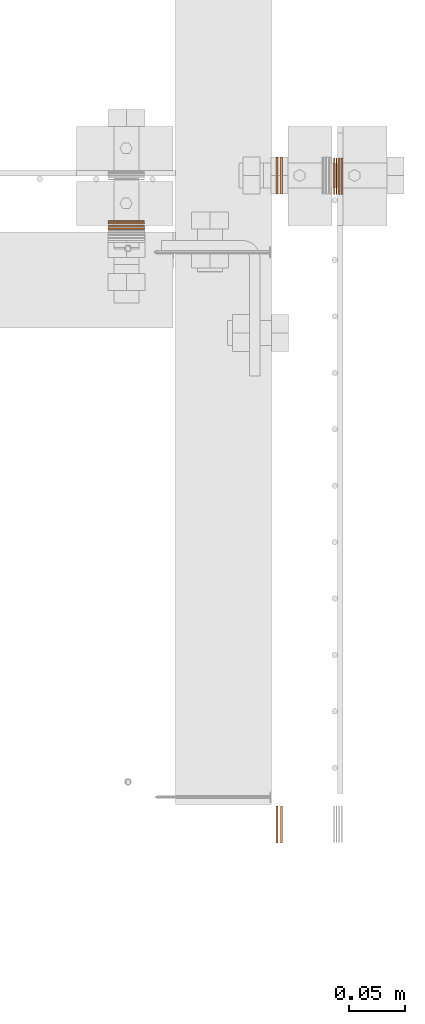
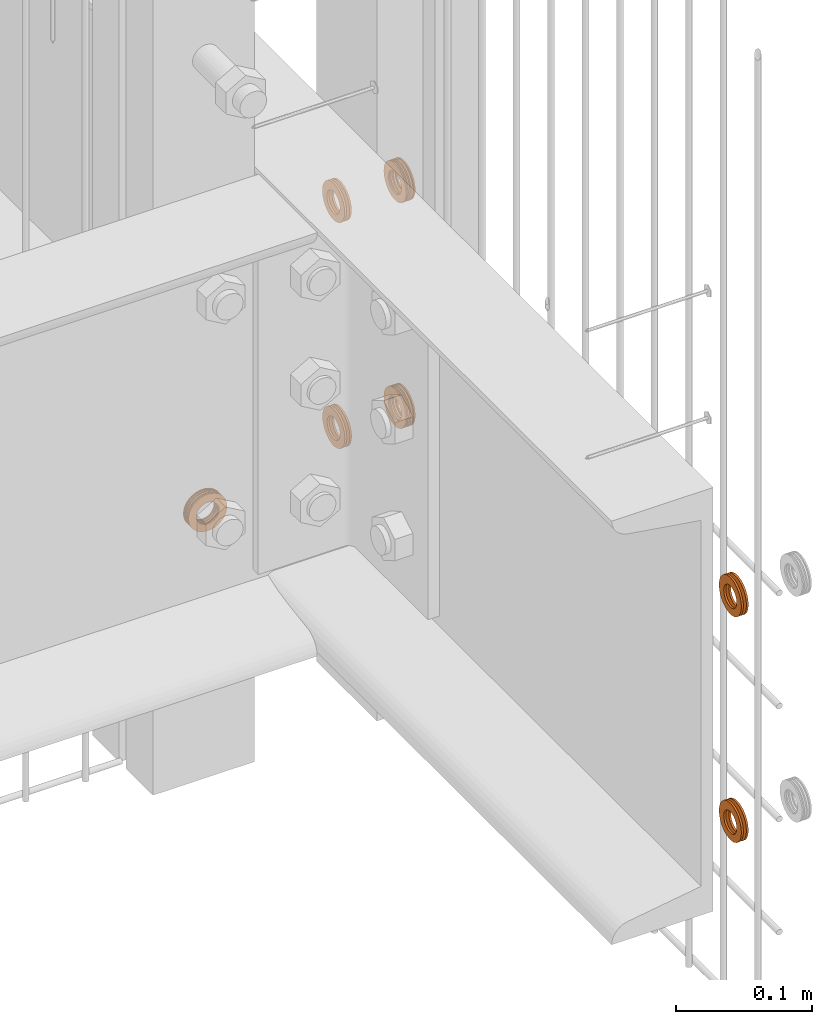
# One storey, part 40 of 44: 7 proxies.
"""IFC4 building model written with IfcOpenShell, lengths in feet."""

from ifc_helpers import new_model, entity, si_unit, converted_unit, derived_unit, direction, frame, frame_2d, origin, origin_2d_with_axis, place, context, subcontext, project, spatial, circle_curve, parameter, trimmed, segment, composite_curve, outline, extrude, source, transform, mapped, material, type_object, type_shapes, element, save


model = new_model("IFC4")

# Units and contexts
model_context = context("Model", 3, precision=0.0001, world=origin(), true_north=direction((6.12303176911189e-17, 1.0)))
body_context = subcontext(model_context, "Body", "Model", "MODEL_VIEW")
ifc_project = project(units=[converted_unit("LENGTHUNIT", "FOOT", entity("IfcRatioMeasure", 0.3048), si_unit("LENGTHUNIT", "METRE"), dimensions=[1, 0, 0, 0, 0, 0, 0]), converted_unit("AREAUNIT", "SQUARE FOOT", entity("IfcRatioMeasure", 0.09290304), si_unit("AREAUNIT", "SQUARE_METRE"), dimensions=[2, 0, 0, 0, 0, 0, 0]), converted_unit("VOLUMEUNIT", "CUBIC FOOT", entity("IfcRatioMeasure", 0.028316846592), si_unit("VOLUMEUNIT", "CUBIC_METRE"), dimensions=[3, 0, 0, 0, 0, 0, 0]), converted_unit("PLANEANGLEUNIT", "DEGREE", entity("IfcRatioMeasure", 0.0174532925199433), si_unit("PLANEANGLEUNIT", "RADIAN"), dimensions=[0, 0, 0, 0, 0, 0, 0]), si_unit("MASSUNIT", "GRAM", prefix="KILO"), derived_unit("MASSDENSITYUNIT", [(si_unit("MASSUNIT", "GRAM", prefix="KILO"), 1), (si_unit("LENGTHUNIT", "METRE"), -3)]), derived_unit("MOMENTOFINERTIAUNIT", [(si_unit("LENGTHUNIT", "METRE"), 4)]), si_unit("TIMEUNIT", "SECOND"), si_unit("FREQUENCYUNIT", "HERTZ"), si_unit("THERMODYNAMICTEMPERATUREUNIT", "DEGREE_CELSIUS"), derived_unit("THERMALTRANSMITTANCEUNIT", [(si_unit("MASSUNIT", "GRAM", prefix="KILO"), 1), (si_unit("THERMODYNAMICTEMPERATUREUNIT", "KELVIN"), -1), (si_unit("TIMEUNIT", "SECOND"), -3)]), derived_unit("VOLUMETRICFLOWRATEUNIT", [(si_unit("LENGTHUNIT", "METRE"), 3), (si_unit("TIMEUNIT", "SECOND"), -1)]), si_unit("ELECTRICCURRENTUNIT", "AMPERE"), si_unit("ELECTRICVOLTAGEUNIT", "VOLT"), si_unit("POWERUNIT", "WATT"), si_unit("FORCEUNIT", "NEWTON"), si_unit("ILLUMINANCEUNIT", "LUX"), si_unit("LUMINOUSFLUXUNIT", "LUMEN"), si_unit("LUMINOUSINTENSITYUNIT", "CANDELA"), derived_unit("USERDEFINED", [(si_unit("MASSUNIT", "GRAM", prefix="KILO"), -1), (si_unit("LENGTHUNIT", "METRE"), -2), (si_unit("TIMEUNIT", "SECOND"), 3), (si_unit("LUMINOUSFLUXUNIT", "LUMEN"), 1)]), derived_unit("LINEARVELOCITYUNIT", [(si_unit("LENGTHUNIT", "METRE"), 1), (si_unit("TIMEUNIT", "SECOND"), -1)]), si_unit("PRESSUREUNIT", "PASCAL"), derived_unit("USERDEFINED", [(si_unit("LENGTHUNIT", "METRE"), -2), (si_unit("MASSUNIT", "GRAM", prefix="KILO"), 1), (si_unit("TIMEUNIT", "SECOND"), -2)]), derived_unit("LINEARFORCEUNIT", [(si_unit("MASSUNIT", "GRAM", prefix="KILO"), 1), (si_unit("LENGTHUNIT", "METRE"), 1), (si_unit("TIMEUNIT", "SECOND"), -2), (si_unit("LENGTHUNIT", "METRE"), -1)]), derived_unit("PLANARFORCEUNIT", [(si_unit("MASSUNIT", "GRAM", prefix="KILO"), 1), (si_unit("LENGTHUNIT", "METRE"), 1), (si_unit("TIMEUNIT", "SECOND"), -2), (si_unit("LENGTHUNIT", "METRE"), -2)])], contexts=[model_context])

# Site, building, storey
site_placement = place(None, origin())
site = spatial("IfcSite", under=ifc_project, at=site_placement, CompositionType="ELEMENT")
building_placement = place(site_placement, origin())
building = spatial("IfcBuilding", under=site, at=building_placement, CompositionType="ELEMENT")
storey_placement = place(building_placement, origin())
storey = spatial("IfcBuildingStorey", under=building, at=storey_placement, CompositionType="ELEMENT", Elevation=0.0)

# Proxies
ifc_material = material(Name="(2) GALV. (FOR DRAINAGE)", Category="Materials")
building_element_proxy_type_1 = type_object("IfcBuildingElementProxyType", Name="WASHER200:WASHER", PredefinedType="NOTDEFINED", material=ifc_material)
shared_shape_1 = source(origin(), body_context, "Body", "SweptSolid", [
    extrude(outline(composite_curve([segment(trimmed(circle_curve(origin_2d_with_axis(), 0.054126587736544), [parameter(360.0)], [parameter(180.0)], True, "PARAMETER"), True, "CONTINUOUS"), segment(trimmed(circle_curve(origin_2d_with_axis(), 0.054126587736544), [parameter(180.0)], [parameter(360.0)], True, "PARAMETER"), True, "CONTINUOUS")], self_intersect=False), holes=[composite_curve([segment(trimmed(circle_curve(frame_2d((0.0, 0.00204962727015712), x_axis=(1.0, 0.0)), 0.031438579453031), [parameter(180.0)], [parameter(360.0)], True, "PARAMETER"), False, "CONTINUOUS"), segment(trimmed(circle_curve(frame_2d((0.0, 0.00204962727015712), x_axis=(1.0, 0.0)), 0.031438579453031), [parameter(360.0)], [parameter(180.0)], True, "PARAMETER"), False, "CONTINUOUS")], self_intersect=False)]), frame((0.0, 0.0593604205315437, 0.0593604205315437), z_axis=(1.0, 0.0, 0.0), x_axis=(0.0, -1.0, 0.0)), (0.0, 0.0, 1.0), 0.00332179672204802),
    extrude(outline(composite_curve([segment(trimmed(circle_curve(origin_2d_with_axis(), 0.054126587736544), [parameter(180.0)], [parameter(360.0)], True, "PARAMETER"), True, "CONTINUOUS"), segment(trimmed(circle_curve(origin_2d_with_axis(), 0.054126587736544), [parameter(360.0)], [parameter(180.0)], True, "PARAMETER"), True, "CONTINUOUS")], self_intersect=False), holes=[composite_curve([segment(trimmed(circle_curve(frame_2d((0.0, 0.00204962727015712), x_axis=(1.0, 0.0)), 0.031438579453031), [parameter(360.0)], [parameter(180.0)], True, "PARAMETER"), False, "CONTINUOUS"), segment(trimmed(circle_curve(frame_2d((0.0, 0.00204962727015712), x_axis=(1.0, 0.0)), 0.031438579453031), [parameter(180.0)], [parameter(360.0)], True, "PARAMETER"), False, "CONTINUOUS")], self_intersect=False)]), frame((0.0220636819910851, 0.0593604205315437, 0.0593604205315437), z_axis=(1.0, 0.0, 0.0), x_axis=(0.0, -1.0, 0.0)), (0.0, 0.0, 1.0), 0.00404999031002262),
    extrude(outline(composite_curve([segment(trimmed(circle_curve(origin_2d_with_axis(), 0.054126587736544), [parameter(180.0)], [parameter(360.0)], True, "PARAMETER"), True, "CONTINUOUS"), segment(trimmed(circle_curve(origin_2d_with_axis(), 0.054126587736544), [parameter(360.0)], [parameter(180.0)], True, "PARAMETER"), True, "CONTINUOUS")], self_intersect=False), holes=[composite_curve([segment(trimmed(circle_curve(frame_2d((0.0, 0.00204962727015712), x_axis=(1.0, 0.0)), 0.031438579453031), [parameter(360.0)], [parameter(180.0)], True, "PARAMETER"), False, "CONTINUOUS"), segment(trimmed(circle_curve(frame_2d((0.0, 0.00204962727015712), x_axis=(1.0, 0.0)), 0.031438579453031), [parameter(180.0)], [parameter(360.0)], True, "PARAMETER"), False, "CONTINUOUS")], self_intersect=False)]), frame((0.00642093526334975, 0.0593604205315437, 0.0593604205315437), z_axis=(1.0, 0.0, 0.0), x_axis=(0.0, -1.0, 0.0)), (0.0, 0.0, 1.0), 0.00412198282083409),
    extrude(outline(composite_curve([segment(trimmed(circle_curve(origin_2d_with_axis(), 0.054126587736544), [parameter(180.0)], [parameter(360.0)], True, "PARAMETER"), True, "CONTINUOUS"), segment(trimmed(circle_curve(origin_2d_with_axis(), 0.054126587736544), [parameter(360.0)], [parameter(180.0)], True, "PARAMETER"), True, "CONTINUOUS")], self_intersect=False), holes=[composite_curve([segment(trimmed(circle_curve(frame_2d((0.0, 0.00204962727015712), x_axis=(1.0, 0.0)), 0.031438579453031), [parameter(360.0)], [parameter(180.0)], True, "PARAMETER"), False, "CONTINUOUS"), segment(trimmed(circle_curve(frame_2d((0.0, 0.00204962727015712), x_axis=(1.0, 0.0)), 0.031438579453031), [parameter(180.0)], [parameter(360.0)], True, "PARAMETER"), False, "CONTINUOUS")], self_intersect=False)]), frame((0.0141095597130061, 0.0593604205315437, 0.0593604205315437), z_axis=(1.0, 0.0, 0.0), x_axis=(0.0, -1.0, 0.0)), (0.0, 0.0, 1.0), 0.0051228935196832),
])
type_shapes(building_element_proxy_type_1, [shared_shape_1])
proxy_1_placement = place(storey_placement, frame((1493.80418979036, 4.77190511208776, 8.90822083537735), z_axis=(0.0, 0.0, 1.0), x_axis=(0.0, -1.0, 0.0)))
element("IfcBuildingElementProxy", 1, at=proxy_1_placement, inside=storey, type_object=building_element_proxy_type_1, material=ifc_material, Name="WASHER200:WASHER", ObjectType="WASHER200:WASHER", PredefinedType="NOTDEFINED", context=body_context, shape_type="MappedRepresentation", body=[
    mapped(shared_shape_1, transform((0.0, 0.0, 0.0), scale=1.0)),
])
building_element_proxy_type_2 = type_object("IfcBuildingElementProxyType", Name="WASHER309:WASHER", PredefinedType="NOTDEFINED", material=ifc_material)
shared_shape_2 = source(origin(), body_context, "Body", "SweptSolid", [
    extrude(outline(composite_curve([segment(trimmed(circle_curve(origin_2d_with_axis(), 0.054126587736544), [parameter(360.0)], [parameter(180.0)], True, "PARAMETER"), True, "CONTINUOUS"), segment(trimmed(circle_curve(origin_2d_with_axis(), 0.054126587736544), [parameter(180.0)], [parameter(360.0)], True, "PARAMETER"), True, "CONTINUOUS")], self_intersect=False), holes=[composite_curve([segment(trimmed(circle_curve(frame_2d((0.0, 0.00204962727015712), x_axis=(1.0, 0.0)), 0.031438579453031), [parameter(180.0)], [parameter(360.0)], True, "PARAMETER"), False, "CONTINUOUS"), segment(trimmed(circle_curve(frame_2d((0.0, 0.00204962727015712), x_axis=(1.0, 0.0)), 0.031438579453031), [parameter(360.0)], [parameter(180.0)], True, "PARAMETER"), False, "CONTINUOUS")], self_intersect=False)]), frame((0.0, 0.0593604205315437, 0.0593604205315437), z_axis=(1.0, 0.0, 0.0), x_axis=(0.0, -1.0, 0.0)), (0.0, 0.0, 1.0), 0.00332179672204802),
    extrude(outline(composite_curve([segment(trimmed(circle_curve(origin_2d_with_axis(), 0.054126587736544), [parameter(180.0)], [parameter(360.0)], True, "PARAMETER"), True, "CONTINUOUS"), segment(trimmed(circle_curve(origin_2d_with_axis(), 0.054126587736544), [parameter(360.0)], [parameter(180.0)], True, "PARAMETER"), True, "CONTINUOUS")], self_intersect=False), holes=[composite_curve([segment(trimmed(circle_curve(frame_2d((0.0, 0.00204962727015712), x_axis=(1.0, 0.0)), 0.031438579453031), [parameter(360.0)], [parameter(180.0)], True, "PARAMETER"), False, "CONTINUOUS"), segment(trimmed(circle_curve(frame_2d((0.0, 0.00204962727015712), x_axis=(1.0, 0.0)), 0.031438579453031), [parameter(180.0)], [parameter(360.0)], True, "PARAMETER"), False, "CONTINUOUS")], self_intersect=False)]), frame((0.0220636819910851, 0.0593604205315437, 0.0593604205315437), z_axis=(1.0, 0.0, 0.0), x_axis=(0.0, -1.0, 0.0)), (0.0, 0.0, 1.0), 0.00404999031002262),
    extrude(outline(composite_curve([segment(trimmed(circle_curve(origin_2d_with_axis(), 0.054126587736544), [parameter(180.0)], [parameter(360.0)], True, "PARAMETER"), True, "CONTINUOUS"), segment(trimmed(circle_curve(origin_2d_with_axis(), 0.054126587736544), [parameter(360.0)], [parameter(180.0)], True, "PARAMETER"), True, "CONTINUOUS")], self_intersect=False), holes=[composite_curve([segment(trimmed(circle_curve(frame_2d((0.0, 0.00204962727015712), x_axis=(1.0, 0.0)), 0.031438579453031), [parameter(360.0)], [parameter(180.0)], True, "PARAMETER"), False, "CONTINUOUS"), segment(trimmed(circle_curve(frame_2d((0.0, 0.00204962727015712), x_axis=(1.0, 0.0)), 0.031438579453031), [parameter(180.0)], [parameter(360.0)], True, "PARAMETER"), False, "CONTINUOUS")], self_intersect=False)]), frame((0.00642093526334975, 0.0593604205315437, 0.0593604205315437), z_axis=(1.0, 0.0, 0.0), x_axis=(0.0, -1.0, 0.0)), (0.0, 0.0, 1.0), 0.00412198282083409),
    extrude(outline(composite_curve([segment(trimmed(circle_curve(origin_2d_with_axis(), 0.054126587736544), [parameter(180.0)], [parameter(360.0)], True, "PARAMETER"), True, "CONTINUOUS"), segment(trimmed(circle_curve(origin_2d_with_axis(), 0.054126587736544), [parameter(360.0)], [parameter(180.0)], True, "PARAMETER"), True, "CONTINUOUS")], self_intersect=False), holes=[composite_curve([segment(trimmed(circle_curve(frame_2d((0.0, 0.00204962727015712), x_axis=(1.0, 0.0)), 0.031438579453031), [parameter(360.0)], [parameter(180.0)], True, "PARAMETER"), False, "CONTINUOUS"), segment(trimmed(circle_curve(frame_2d((0.0, 0.00204962727015712), x_axis=(1.0, 0.0)), 0.031438579453031), [parameter(180.0)], [parameter(360.0)], True, "PARAMETER"), False, "CONTINUOUS")], self_intersect=False)]), frame((0.0141095597130061, 0.0593604205315437, 0.0593604205315437), z_axis=(1.0, 0.0, 0.0), x_axis=(0.0, -1.0, 0.0)), (0.0, 0.0, 1.0), 0.0051228935196832),
])
type_shapes(building_element_proxy_type_2, [shared_shape_2])
proxy_2_placement = place(storey_placement, frame((1494.47651830938, 4.84385605947604, 9.57411707518479)))
element("IfcBuildingElementProxy", 2, at=proxy_2_placement, inside=storey, type_object=building_element_proxy_type_2, material=ifc_material, Name="WASHER309:WASHER", ObjectType="WASHER309:WASHER", PredefinedType="NOTDEFINED", context=body_context, shape_type="MappedRepresentation", body=[
    mapped(shared_shape_2, transform((0.0, 0.0, 0.0), scale=1.0)),
])
building_element_proxy_type_3 = type_object("IfcBuildingElementProxyType", Name="WASHER315:WASHER", PredefinedType="NOTDEFINED", material=ifc_material)
shared_shape_3 = source(origin(), body_context, "Body", "SweptSolid", [
    extrude(outline(composite_curve([segment(trimmed(circle_curve(origin_2d_with_axis(), 0.054126587736544), [parameter(360.0)], [parameter(180.0)], True, "PARAMETER"), True, "CONTINUOUS"), segment(trimmed(circle_curve(origin_2d_with_axis(), 0.054126587736544), [parameter(180.0)], [parameter(360.0)], True, "PARAMETER"), True, "CONTINUOUS")], self_intersect=False), holes=[composite_curve([segment(trimmed(circle_curve(frame_2d((0.0, 0.00204962727015712), x_axis=(1.0, 0.0)), 0.031438579453031), [parameter(180.0)], [parameter(360.0)], True, "PARAMETER"), False, "CONTINUOUS"), segment(trimmed(circle_curve(frame_2d((0.0, 0.00204962727015712), x_axis=(1.0, 0.0)), 0.031438579453031), [parameter(360.0)], [parameter(180.0)], True, "PARAMETER"), False, "CONTINUOUS")], self_intersect=False)]), frame((0.0, 0.0593604205315437, 0.0593604205315437), z_axis=(1.0, 0.0, 0.0), x_axis=(0.0, -1.0, 0.0)), (0.0, 0.0, 1.0), 0.00332179672204802),
    extrude(outline(composite_curve([segment(trimmed(circle_curve(origin_2d_with_axis(), 0.054126587736544), [parameter(180.0)], [parameter(360.0)], True, "PARAMETER"), True, "CONTINUOUS"), segment(trimmed(circle_curve(origin_2d_with_axis(), 0.054126587736544), [parameter(360.0)], [parameter(180.0)], True, "PARAMETER"), True, "CONTINUOUS")], self_intersect=False), holes=[composite_curve([segment(trimmed(circle_curve(frame_2d((0.0, 0.00204962727015712), x_axis=(1.0, 0.0)), 0.031438579453031), [parameter(360.0)], [parameter(180.0)], True, "PARAMETER"), False, "CONTINUOUS"), segment(trimmed(circle_curve(frame_2d((0.0, 0.00204962727015712), x_axis=(1.0, 0.0)), 0.031438579453031), [parameter(180.0)], [parameter(360.0)], True, "PARAMETER"), False, "CONTINUOUS")], self_intersect=False)]), frame((0.0220636819910851, 0.0593604205315437, 0.0593604205315437), z_axis=(1.0, 0.0, 0.0), x_axis=(0.0, -1.0, 0.0)), (0.0, 0.0, 1.0), 0.00404999031002262),
    extrude(outline(composite_curve([segment(trimmed(circle_curve(origin_2d_with_axis(), 0.054126587736544), [parameter(180.0)], [parameter(360.0)], True, "PARAMETER"), True, "CONTINUOUS"), segment(trimmed(circle_curve(origin_2d_with_axis(), 0.054126587736544), [parameter(360.0)], [parameter(180.0)], True, "PARAMETER"), True, "CONTINUOUS")], self_intersect=False), holes=[composite_curve([segment(trimmed(circle_curve(frame_2d((0.0, 0.00204962727015712), x_axis=(1.0, 0.0)), 0.031438579453031), [parameter(360.0)], [parameter(180.0)], True, "PARAMETER"), False, "CONTINUOUS"), segment(trimmed(circle_curve(frame_2d((0.0, 0.00204962727015712), x_axis=(1.0, 0.0)), 0.031438579453031), [parameter(180.0)], [parameter(360.0)], True, "PARAMETER"), False, "CONTINUOUS")], self_intersect=False)]), frame((0.00642093526334975, 0.0593604205315437, 0.0593604205315437), z_axis=(1.0, 0.0, 0.0), x_axis=(0.0, -1.0, 0.0)), (0.0, 0.0, 1.0), 0.00412198282083409),
    extrude(outline(composite_curve([segment(trimmed(circle_curve(origin_2d_with_axis(), 0.054126587736544), [parameter(180.0)], [parameter(360.0)], True, "PARAMETER"), True, "CONTINUOUS"), segment(trimmed(circle_curve(origin_2d_with_axis(), 0.054126587736544), [parameter(360.0)], [parameter(180.0)], True, "PARAMETER"), True, "CONTINUOUS")], self_intersect=False), holes=[composite_curve([segment(trimmed(circle_curve(frame_2d((0.0, 0.00204962727015712), x_axis=(1.0, 0.0)), 0.031438579453031), [parameter(360.0)], [parameter(180.0)], True, "PARAMETER"), False, "CONTINUOUS"), segment(trimmed(circle_curve(frame_2d((0.0, 0.00204962727015712), x_axis=(1.0, 0.0)), 0.031438579453031), [parameter(180.0)], [parameter(360.0)], True, "PARAMETER"), False, "CONTINUOUS")], self_intersect=False)]), frame((0.0141095597130061, 0.0593604205315437, 0.0593604205315437), z_axis=(1.0, 0.0, 0.0), x_axis=(0.0, -1.0, 0.0)), (0.0, 0.0, 1.0), 0.0051228935196832),
])
type_shapes(building_element_proxy_type_3, [shared_shape_3])
proxy_3_placement = place(storey_placement, frame((1494.47651830938, 4.84385605947604, 8.90822083537673)))
element("IfcBuildingElementProxy", 3, at=proxy_3_placement, inside=storey, type_object=building_element_proxy_type_3, material=ifc_material, Name="WASHER315:WASHER", ObjectType="WASHER315:WASHER", PredefinedType="NOTDEFINED", context=body_context, shape_type="MappedRepresentation", body=[
    mapped(shared_shape_3, transform((0.0, 0.0, 0.0), scale=1.0)),
])
building_element_proxy_type_4 = type_object("IfcBuildingElementProxyType", Name="WASHER321:WASHER", PredefinedType="NOTDEFINED", material=ifc_material)
shared_shape_4 = source(origin(), body_context, "Body", "SweptSolid", [
    extrude(outline(composite_curve([segment(trimmed(circle_curve(origin_2d_with_axis(), 0.054126587736544), [parameter(360.0)], [parameter(180.0)], True, "PARAMETER"), True, "CONTINUOUS"), segment(trimmed(circle_curve(origin_2d_with_axis(), 0.054126587736544), [parameter(180.0)], [parameter(360.0)], True, "PARAMETER"), True, "CONTINUOUS")], self_intersect=False), holes=[composite_curve([segment(trimmed(circle_curve(frame_2d((0.0, 0.00204962727015712), x_axis=(1.0, 0.0)), 0.031438579453031), [parameter(180.0)], [parameter(360.0)], True, "PARAMETER"), False, "CONTINUOUS"), segment(trimmed(circle_curve(frame_2d((0.0, 0.00204962727015712), x_axis=(1.0, 0.0)), 0.031438579453031), [parameter(360.0)], [parameter(180.0)], True, "PARAMETER"), False, "CONTINUOUS")], self_intersect=False)]), frame((0.0, 0.0593604205315437, 0.0593604205315437), z_axis=(1.0, 0.0, 0.0), x_axis=(0.0, -1.0, 0.0)), (0.0, 0.0, 1.0), 0.00567364184894359),
    extrude(outline(composite_curve([segment(trimmed(circle_curve(origin_2d_with_axis(), 0.054126587736544), [parameter(180.0)], [parameter(360.0)], True, "PARAMETER"), True, "CONTINUOUS"), segment(trimmed(circle_curve(origin_2d_with_axis(), 0.054126587736544), [parameter(360.0)], [parameter(180.0)], True, "PARAMETER"), True, "CONTINUOUS")], self_intersect=False), holes=[composite_curve([segment(trimmed(circle_curve(frame_2d((0.0, 0.00204962727015712), x_axis=(1.0, 0.0)), 0.031438579453031), [parameter(360.0)], [parameter(180.0)], True, "PARAMETER"), False, "CONTINUOUS"), segment(trimmed(circle_curve(frame_2d((0.0, 0.00204962727015712), x_axis=(1.0, 0.0)), 0.031438579453031), [parameter(180.0)], [parameter(360.0)], True, "PARAMETER"), False, "CONTINUOUS")], self_intersect=False)]), frame((0.0139588239010209, 0.0593604205315437, 0.0593604205315437), z_axis=(1.0, 0.0, 0.0), x_axis=(0.0, -1.0, 0.0)), (0.0, 0.0, 1.0), 0.00565953758882642),
])
type_shapes(building_element_proxy_type_4, [shared_shape_4])
proxy_4_placement = place(storey_placement, frame((1494.306098952, 2.92811881328394, 8.90822083537673)))
element("IfcBuildingElementProxy", 4, at=proxy_4_placement, inside=storey, type_object=building_element_proxy_type_4, material=ifc_material, Name="WASHER321:WASHER", ObjectType="WASHER321:WASHER", PredefinedType="NOTDEFINED", context=body_context, shape_type="MappedRepresentation", body=[
    mapped(shared_shape_4, transform((0.0, 0.0, 0.0), scale=1.0)),
])
building_element_proxy_type_5 = type_object("IfcBuildingElementProxyType", Name="WASHER195:WASHER", PredefinedType="NOTDEFINED", material=ifc_material)
shared_shape_5 = source(origin(), body_context, "Body", "SweptSolid", [
    extrude(outline(composite_curve([segment(trimmed(circle_curve(origin_2d_with_axis(), 0.054126587736544), [parameter(360.0)], [parameter(180.0)], True, "PARAMETER"), True, "CONTINUOUS"), segment(trimmed(circle_curve(origin_2d_with_axis(), 0.054126587736544), [parameter(180.0)], [parameter(360.0)], True, "PARAMETER"), True, "CONTINUOUS")], self_intersect=False), holes=[composite_curve([segment(trimmed(circle_curve(frame_2d((0.0, 0.00204962727015712), x_axis=(1.0, 0.0)), 0.031438579453031), [parameter(180.0)], [parameter(360.0)], True, "PARAMETER"), False, "CONTINUOUS"), segment(trimmed(circle_curve(frame_2d((0.0, 0.00204962727015712), x_axis=(1.0, 0.0)), 0.031438579453031), [parameter(360.0)], [parameter(180.0)], True, "PARAMETER"), False, "CONTINUOUS")], self_intersect=False)]), frame((0.0, 0.0593604205315437, 0.0593604205315437), z_axis=(1.0, 0.0, 0.0), x_axis=(0.0, -1.0, 0.0)), (0.0, 0.0, 1.0), 0.00567364184894359),
    extrude(outline(composite_curve([segment(trimmed(circle_curve(origin_2d_with_axis(), 0.054126587736544), [parameter(180.0)], [parameter(360.0)], True, "PARAMETER"), True, "CONTINUOUS"), segment(trimmed(circle_curve(origin_2d_with_axis(), 0.054126587736544), [parameter(360.0)], [parameter(180.0)], True, "PARAMETER"), True, "CONTINUOUS")], self_intersect=False), holes=[composite_curve([segment(trimmed(circle_curve(frame_2d((0.0, 0.00204962727015712), x_axis=(1.0, 0.0)), 0.031438579453031), [parameter(360.0)], [parameter(180.0)], True, "PARAMETER"), False, "CONTINUOUS"), segment(trimmed(circle_curve(frame_2d((0.0, 0.00204962727015712), x_axis=(1.0, 0.0)), 0.031438579453031), [parameter(180.0)], [parameter(360.0)], True, "PARAMETER"), False, "CONTINUOUS")], self_intersect=False)]), frame((0.0139588239010209, 0.0593604205315437, 0.0593604205315437), z_axis=(1.0, 0.0, 0.0), x_axis=(0.0, -1.0, 0.0)), (0.0, 0.0, 1.0), 0.00565953758882642),
])
type_shapes(building_element_proxy_type_5, [shared_shape_5])
proxy_5_placement = place(storey_placement, frame((1494.306098952, 2.92811881328394, 9.57411707518479)))
element("IfcBuildingElementProxy", 5, at=proxy_5_placement, inside=storey, type_object=building_element_proxy_type_5, material=ifc_material, Name="WASHER195:WASHER", ObjectType="WASHER195:WASHER", PredefinedType="NOTDEFINED", context=body_context, shape_type="MappedRepresentation", body=[
    mapped(shared_shape_5, transform((0.0, 0.0, 0.0), scale=1.0)),
])
building_element_proxy_type_6 = type_object("IfcBuildingElementProxyType", Name="WASHER196:WASHER", PredefinedType="NOTDEFINED", material=ifc_material)
shared_shape_6 = source(origin(), body_context, "Body", "SweptSolid", [
    extrude(outline(composite_curve([segment(trimmed(circle_curve(origin_2d_with_axis(), 0.054126587736544), [parameter(360.0)], [parameter(180.0)], True, "PARAMETER"), True, "CONTINUOUS"), segment(trimmed(circle_curve(origin_2d_with_axis(), 0.054126587736544), [parameter(180.0)], [parameter(360.0)], True, "PARAMETER"), True, "CONTINUOUS")], self_intersect=False), holes=[composite_curve([segment(trimmed(circle_curve(frame_2d((0.0, 0.00204962727015712), x_axis=(1.0, 0.0)), 0.031438579453031), [parameter(180.0)], [parameter(360.0)], True, "PARAMETER"), False, "CONTINUOUS"), segment(trimmed(circle_curve(frame_2d((0.0, 0.00204962727015712), x_axis=(1.0, 0.0)), 0.031438579453031), [parameter(360.0)], [parameter(180.0)], True, "PARAMETER"), False, "CONTINUOUS")], self_intersect=False)]), frame((0.0, 0.0593604205315437, 0.0593604205315437), z_axis=(1.0, 0.0, 0.0), x_axis=(0.0, -1.0, 0.0)), (0.0, 0.0, 1.0), 0.00567364184894359),
    extrude(outline(composite_curve([segment(trimmed(circle_curve(origin_2d_with_axis(), 0.054126587736544), [parameter(180.0)], [parameter(360.0)], True, "PARAMETER"), True, "CONTINUOUS"), segment(trimmed(circle_curve(origin_2d_with_axis(), 0.054126587736544), [parameter(360.0)], [parameter(180.0)], True, "PARAMETER"), True, "CONTINUOUS")], self_intersect=False), holes=[composite_curve([segment(trimmed(circle_curve(frame_2d((0.0, 0.00204962727015712), x_axis=(1.0, 0.0)), 0.031438579453031), [parameter(360.0)], [parameter(180.0)], True, "PARAMETER"), False, "CONTINUOUS"), segment(trimmed(circle_curve(frame_2d((0.0, 0.00204962727015712), x_axis=(1.0, 0.0)), 0.031438579453031), [parameter(180.0)], [parameter(360.0)], True, "PARAMETER"), False, "CONTINUOUS")], self_intersect=False)]), frame((0.0139588239010209, 0.0593604205315437, 0.0593604205315437), z_axis=(1.0, 0.0, 0.0), x_axis=(0.0, -1.0, 0.0)), (0.0, 0.0, 1.0), 0.00565953758882642),
])
type_shapes(building_element_proxy_type_6, [shared_shape_6])
proxy_6_placement = place(storey_placement, frame((1494.306098952, 4.8447854799506, 8.90822083537673)))
element("IfcBuildingElementProxy", 6, at=proxy_6_placement, inside=storey, type_object=building_element_proxy_type_6, material=ifc_material, Name="WASHER196:WASHER", ObjectType="WASHER196:WASHER", PredefinedType="NOTDEFINED", context=body_context, shape_type="MappedRepresentation", body=[
    mapped(shared_shape_6, transform((0.0, 0.0, 0.0), scale=1.0)),
])
building_element_proxy_type_7 = type_object("IfcBuildingElementProxyType", Name="WASHER322:WASHER", PredefinedType="NOTDEFINED", material=ifc_material)
shared_shape_7 = source(origin(), body_context, "Body", "SweptSolid", [
    extrude(outline(composite_curve([segment(trimmed(circle_curve(origin_2d_with_axis(), 0.054126587736544), [parameter(360.0)], [parameter(180.0)], True, "PARAMETER"), True, "CONTINUOUS"), segment(trimmed(circle_curve(origin_2d_with_axis(), 0.054126587736544), [parameter(180.0)], [parameter(360.0)], True, "PARAMETER"), True, "CONTINUOUS")], self_intersect=False), holes=[composite_curve([segment(trimmed(circle_curve(frame_2d((0.0, 0.00204962727015712), x_axis=(1.0, 0.0)), 0.031438579453031), [parameter(180.0)], [parameter(360.0)], True, "PARAMETER"), False, "CONTINUOUS"), segment(trimmed(circle_curve(frame_2d((0.0, 0.00204962727015712), x_axis=(1.0, 0.0)), 0.031438579453031), [parameter(360.0)], [parameter(180.0)], True, "PARAMETER"), False, "CONTINUOUS")], self_intersect=False)]), frame((0.0, 0.0593604205315437, 0.0593604205315437), z_axis=(1.0, 0.0, 0.0), x_axis=(0.0, -1.0, 0.0)), (0.0, 0.0, 1.0), 0.00567364184894359),
    extrude(outline(composite_curve([segment(trimmed(circle_curve(origin_2d_with_axis(), 0.054126587736544), [parameter(180.0)], [parameter(360.0)], True, "PARAMETER"), True, "CONTINUOUS"), segment(trimmed(circle_curve(origin_2d_with_axis(), 0.054126587736544), [parameter(360.0)], [parameter(180.0)], True, "PARAMETER"), True, "CONTINUOUS")], self_intersect=False), holes=[composite_curve([segment(trimmed(circle_curve(frame_2d((0.0, 0.00204962727015712), x_axis=(1.0, 0.0)), 0.031438579453031), [parameter(360.0)], [parameter(180.0)], True, "PARAMETER"), False, "CONTINUOUS"), segment(trimmed(circle_curve(frame_2d((0.0, 0.00204962727015712), x_axis=(1.0, 0.0)), 0.031438579453031), [parameter(180.0)], [parameter(360.0)], True, "PARAMETER"), False, "CONTINUOUS")], self_intersect=False)]), frame((0.0139588239010209, 0.0593604205315437, 0.0593604205315437), z_axis=(1.0, 0.0, 0.0), x_axis=(0.0, -1.0, 0.0)), (0.0, 0.0, 1.0), 0.00565953758882642),
])
type_shapes(building_element_proxy_type_7, [shared_shape_7])
proxy_7_placement = place(storey_placement, frame((1494.306098952, 4.84569816361928, 9.57411707518479)))
element("IfcBuildingElementProxy", 7, at=proxy_7_placement, inside=storey, type_object=building_element_proxy_type_7, material=ifc_material, Name="WASHER322:WASHER", ObjectType="WASHER322:WASHER", PredefinedType="NOTDEFINED", context=body_context, shape_type="MappedRepresentation", body=[
    mapped(shared_shape_7, transform((0.0, 0.0, 0.0), scale=1.0)),
])

save(model, "model.ifc")
